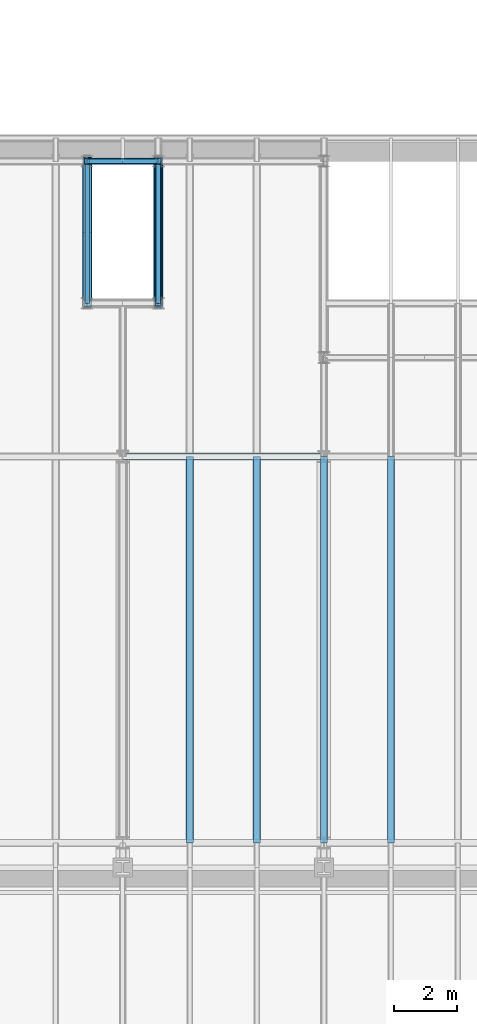
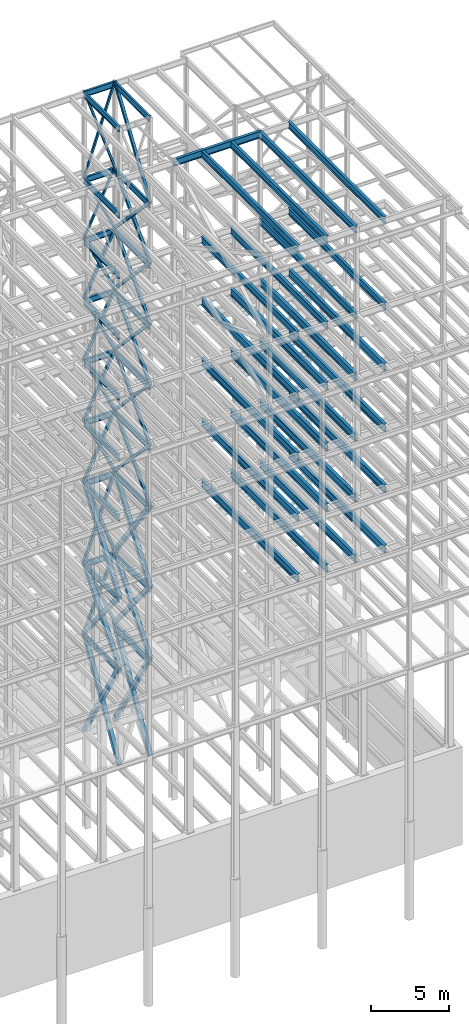
# One storey, part 144 of 150: 89 beams.
"""IFC2X3 building model written with IfcOpenShell, lengths in millimetres."""

from ifc_helpers import new_model, si_unit, frame, origin_with_axes, origin_2d_with_axis, place, context, subcontext, project, spatial, hollow_rectangle, i_section, extrude, material, type_object, element, save


model = new_model("IFC2X3")

# Units and contexts
model_context = context("Model", 3, precision=1e-05, world=origin_with_axes())
body_context = subcontext(model_context, "Body", "Model", "MODEL_VIEW")
ifc_project = project(units=[si_unit("LENGTHUNIT", "METRE", prefix="MILLI"), si_unit("AREAUNIT", "SQUARE_METRE"), si_unit("VOLUMEUNIT", "CUBIC_METRE"), si_unit("MASSUNIT", "GRAM", prefix="KILO"), si_unit("TIMEUNIT", "SECOND"), si_unit("PLANEANGLEUNIT", "RADIAN"), si_unit("SOLIDANGLEUNIT", "STERADIAN"), si_unit("THERMODYNAMICTEMPERATUREUNIT", "DEGREE_CELSIUS"), si_unit("LUMINOUSINTENSITYUNIT", "LUMEN")], contexts=[model_context])

# Site, building, storey
site_placement = place(None, origin_with_axes())
site = spatial("IfcSite", under=ifc_project, at=site_placement, CompositionType="ELEMENT")
building_placement = place(site_placement, origin_with_axes())
building = spatial("IfcBuilding", under=site, at=building_placement, Name="Undefined", CompositionType="ELEMENT")
storey_placement = place(building_placement, origin_with_axes())
storey = spatial("IfcBuildingStorey", under=building, at=storey_placement, Name="Undefined", CompositionType="ELEMENT", Elevation=0.0)

# Beams
ifc_material_1 = material()
beam_type_1 = type_object("IfcBeamType", Name="HSS8X8X3/8", PredefinedType="NOTDEFINED")
for number, where, z_axis, x_axis, name in (
    (1, (76923.9, 31877.0, 40309.8), (0.0, 0.722473115379788, 0.691399014718291), (0.0, -0.691399014718292, 0.722473115379787), "BEAM"),
    (2, (76923.9, 27355.8, 40309.8), (0.0, -0.722473115379788, 0.691399014718291), (0.0, 0.691399014718292, 0.722473115379787), "BEAM"),
    (3, (76923.9, 31877.0, 35585.4), (0.0, 0.722473115379788, 0.691399014718291), (0.0, -0.691399014718292, 0.722473115379787), "BEAM"),
    (4, (76923.9, 27355.8, 35585.4), (0.0, -0.722473115379788, 0.691399014718291), (0.0, 0.691399014718292, 0.722473115379787), "BEAM"),
):
    element("IfcBeam", number, at=place(storey_placement, frame(where, z_axis=z_axis, x_axis=x_axis)), inside=storey, type_object=beam_type_1, material=ifc_material_1, Name=name, ObjectType="HSS8X8X3/8", context=body_context, shape_type="SweptSolid", body=[
        extrude(hollow_rectangle(XDim=203.2, YDim=203.2, WallThickness=9.525, InnerFilletRadius=9.5249, OuterFilletRadius=19.0499, at=origin_2d_with_axis()), frame((6539.20521164461, 0.0, -3.62998809435833e-13), z_axis=(-1.0, 0.0, 0.0), x_axis=(0.0, -1.0, 0.0)), (0.0, 0.0, 1.0), 6539.20521164461),
    ])
for number, where, z_axis, x_axis, name in (
    (5, (76923.9, 31877.0, 40309.8), (0.902052163935922, 0.0, 0.431627030592989), (-0.431627030592989, 0.0, 0.902052163935922), "BEAM"),
    (6, (74663.3, 31877.0, 40309.8), (-0.902052163935922, 0.0, 0.431627030592989), (0.431627030592989, 0.0, 0.902052163935922), "BEAM"),
):
    element("IfcBeam", number, at=place(storey_placement, frame(where, z_axis=z_axis, x_axis=x_axis)), inside=storey, type_object=beam_type_1, material=ifc_material_1, Name=name, ObjectType="HSS8X8X3/8", context=body_context, shape_type="SweptSolid", body=[
        extrude(hollow_rectangle(XDim=203.2, YDim=203.2, WallThickness=9.525, InnerFilletRadius=9.5249, OuterFilletRadius=19.0499, at=origin_2d_with_axis()), frame((5237.3913086574, 0.0, -7.27595761418343e-12), z_axis=(-1.0, 0.0, 0.0), x_axis=(0.0, -1.0, 0.0)), (0.0, 0.0, 1.0), 5237.3913086574),
    ])
beam_1_placement = place(storey_placement, frame((76923.8996893509, 31877.0, 35585.399916514), z_axis=(0.902052163935922, 0.0, 0.431627030592989), x_axis=(-0.431627030592989, 0.0, 0.902052163935922)))
element("IfcBeam", 7, at=beam_1_placement, inside=storey, type_object=beam_type_1, material=ifc_material_1, Name="BEAM", ObjectType="HSS8X8X3/8", context=body_context, shape_type="SweptSolid", body=[
    extrude(hollow_rectangle(XDim=203.2, YDim=203.2, WallThickness=9.525, InnerFilletRadius=9.5249, OuterFilletRadius=19.0499, at=origin_2d_with_axis()), frame((5237.3912468091, 3.63797880709171e-12, 0.0), z_axis=(-1.0, 0.0, 0.0), x_axis=(0.0, -1.0, 0.0)), (0.0, 0.0, 1.0), 5237.39124988153),
])
beam_2_placement = place(storey_placement, frame((74663.3003106491, 31877.0, 35585.399916514), z_axis=(-0.902052163935922, 0.0, 0.431627030592989), x_axis=(0.431627030592989, 0.0, 0.902052163935922)))
element("IfcBeam", 8, at=beam_2_placement, inside=storey, type_object=beam_type_1, material=ifc_material_1, Name="BEAM", ObjectType="HSS8X8X3/8", context=body_context, shape_type="SweptSolid", body=[
    extrude(hollow_rectangle(XDim=203.2, YDim=203.2, WallThickness=9.525, InnerFilletRadius=9.5249, OuterFilletRadius=19.0499, at=origin_2d_with_axis()), frame((5237.3912468091, 3.63797880709171e-12, 0.0), z_axis=(-1.0, 0.0, 0.0), x_axis=(0.0, -1.0, 0.0)), (0.0, 0.0, 1.0), 5237.39124988152),
])
ifc_material_2 = material(Name="STEEL/A992")
beam_type_2 = type_object("IfcBeamType", Name="W18X35", PredefinedType="NOTDEFINED")
beam_3_placement = place(storey_placement, frame((74663.3, 27355.8, 65687.575), z_axis=(0.0, 0.0, 1.0), x_axis=(0.0, 1.0, 0.0)))
element("IfcBeam", 9, at=beam_3_placement, inside=storey, type_object=beam_type_2, material=ifc_material_2, Name="BEAM", ObjectType="W18X35", context=body_context, shape_type="SweptSolid", body=[
    extrude(i_section(OverallWidth=152.4, OverallDepth=450.85, WebThickness=7.9375, FlangeThickness=10.795, FilletRadius=17.78, at=origin_2d_with_axis()), frame((4521.20000000001, 0.0, 0.0), z_axis=(-1.0, 0.0, 0.0), x_axis=(0.0, -1.0, 0.0)), (0.0, 0.0, 1.0), 4521.20000000001),
])
beam_4_placement = place(storey_placement, frame((74663.3, 31877.0, 65687.575), z_axis=(0.0, 0.0, 1.0), x_axis=(1.0, 0.0, 0.0)))
element("IfcBeam", 10, at=beam_4_placement, inside=storey, type_object=beam_type_2, material=ifc_material_2, Name="BEAM", ObjectType="W18X35", context=body_context, shape_type="SweptSolid", body=[
    extrude(i_section(OverallWidth=152.4, OverallDepth=450.85, WebThickness=7.9375, FlangeThickness=10.795, FilletRadius=17.78, at=origin_2d_with_axis()), frame((2260.60000000001, 0.0, 0.0), z_axis=(-1.0, 0.0, 0.0), x_axis=(0.0, -1.0, 0.0)), (0.0, 0.0, 1.0), 2260.60000000001),
])
for number, where, z_axis, x_axis, name in (
    (11, (76923.9, 27355.8, 65687.575), (0.0, 0.0, 1.0), (0.0, 1.0, 0.0), "BEAM"),
    (12, (74663.3, 27355.8, 58981.975), (0.0, 0.0, 1.0), (0.0, 1.0, 0.0), "BEAM"),
):
    element("IfcBeam", number, at=place(storey_placement, frame(where, z_axis=z_axis, x_axis=x_axis)), inside=storey, type_object=beam_type_2, material=ifc_material_2, Name=name, ObjectType="W18X35", context=body_context, shape_type="SweptSolid", body=[
        extrude(i_section(OverallWidth=152.4, OverallDepth=450.85, WebThickness=7.9375, FlangeThickness=10.795, FilletRadius=17.78, at=origin_2d_with_axis()), frame((4521.20000000001, 0.0, 0.0), z_axis=(-1.0, 0.0, 0.0), x_axis=(0.0, -1.0, 0.0)), (0.0, 0.0, 1.0), 4521.20000000001),
    ])
beam_5_placement = place(storey_placement, frame((74663.3, 31877.0, 58981.975), z_axis=(0.0, 0.0, 1.0), x_axis=(1.0, 0.0, 0.0)))
element("IfcBeam", 13, at=beam_5_placement, inside=storey, type_object=beam_type_2, material=ifc_material_2, Name="BEAM", ObjectType="W18X35", context=body_context, shape_type="SweptSolid", body=[
    extrude(i_section(OverallWidth=152.4, OverallDepth=450.85, WebThickness=7.9375, FlangeThickness=10.795, FilletRadius=17.78, at=origin_2d_with_axis()), frame((2260.60000000001, 0.0, 0.0), z_axis=(-1.0, 0.0, 0.0), x_axis=(0.0, -1.0, 0.0)), (0.0, 0.0, 1.0), 2260.60000000001),
])
beam_6_placement = place(storey_placement, frame((76923.9, 27355.8, 58981.975), z_axis=(0.0, 0.0, 1.0), x_axis=(0.0, 1.0, 0.0)))
element("IfcBeam", 14, at=beam_6_placement, inside=storey, type_object=beam_type_2, material=ifc_material_2, Name="BEAM", ObjectType="W18X35", context=body_context, shape_type="SweptSolid", body=[
    extrude(i_section(OverallWidth=152.4, OverallDepth=450.85, WebThickness=7.9375, FlangeThickness=10.795, FilletRadius=17.78, at=origin_2d_with_axis()), frame((4521.20000000001, 0.0, 0.0), z_axis=(-1.0, 0.0, 0.0), x_axis=(0.0, -1.0, 0.0)), (0.0, 0.0, 1.0), 4521.20000000001),
])
beam_7_placement = place(storey_placement, frame((74663.3, 31877.0, 54257.575), z_axis=(0.0, 0.0, 1.0), x_axis=(1.0, 0.0, 0.0)))
element("IfcBeam", 15, at=beam_7_placement, inside=storey, type_object=beam_type_2, material=ifc_material_2, Name="BEAM", ObjectType="W18X35", context=body_context, shape_type="SweptSolid", body=[
    extrude(i_section(OverallWidth=152.4, OverallDepth=450.85, WebThickness=7.9375, FlangeThickness=10.795, FilletRadius=17.78, at=origin_2d_with_axis()), frame((2260.60000000001, 0.0, 0.0), z_axis=(-1.0, 0.0, 0.0), x_axis=(0.0, -1.0, 0.0)), (0.0, 0.0, 1.0), 2260.60000000001),
])
for number, where, z_axis, x_axis, name in (
    (16, (76923.9, 27355.8, 54257.575), (0.0, 0.0, 1.0), (0.0, 1.0, 0.0), "BEAM"),
    (17, (74663.3, 31877.0, 54257.575), (0.0, 0.0, 1.0), (0.0, -1.0, 0.0), "BEAM"),
):
    element("IfcBeam", number, at=place(storey_placement, frame(where, z_axis=z_axis, x_axis=x_axis)), inside=storey, type_object=beam_type_2, material=ifc_material_2, Name=name, ObjectType="W18X35", context=body_context, shape_type="SweptSolid", body=[
        extrude(i_section(OverallWidth=152.4, OverallDepth=450.85, WebThickness=7.9375, FlangeThickness=10.795, FilletRadius=17.78, at=origin_2d_with_axis()), frame((4521.20000000001, 0.0, 0.0), z_axis=(-1.0, 0.0, 0.0), x_axis=(0.0, -1.0, 0.0)), (0.0, 0.0, 1.0), 4521.20000000001),
    ])
beam_8_placement = place(storey_placement, frame((74663.3, 31877.0, 49533.175), z_axis=(0.0, 0.0, 1.0), x_axis=(1.0, 0.0, 0.0)))
element("IfcBeam", 18, at=beam_8_placement, inside=storey, type_object=beam_type_2, material=ifc_material_2, Name="BEAM", ObjectType="W18X35", context=body_context, shape_type="SweptSolid", body=[
    extrude(i_section(OverallWidth=152.4, OverallDepth=450.85, WebThickness=7.9375, FlangeThickness=10.795, FilletRadius=17.78, at=origin_2d_with_axis()), frame((2260.60000000001, 0.0, 0.0), z_axis=(-1.0, 0.0, 0.0), x_axis=(0.0, -1.0, 0.0)), (0.0, 0.0, 1.0), 2260.60000000001),
])
for number, where, z_axis, x_axis, name in (
    (19, (76923.9, 27355.8, 49533.175), (0.0, 0.0, 1.0), (0.0, 1.0, 0.0), "BEAM"),
    (20, (74663.3, 31877.0, 49533.175), (0.0, 0.0, 1.0), (0.0, -1.0, 0.0), "BEAM"),
):
    element("IfcBeam", number, at=place(storey_placement, frame(where, z_axis=z_axis, x_axis=x_axis)), inside=storey, type_object=beam_type_2, material=ifc_material_2, Name=name, ObjectType="W18X35", context=body_context, shape_type="SweptSolid", body=[
        extrude(i_section(OverallWidth=152.4, OverallDepth=450.85, WebThickness=7.9375, FlangeThickness=10.795, FilletRadius=17.78, at=origin_2d_with_axis()), frame((4521.20000000001, 0.0, 0.0), z_axis=(-1.0, 0.0, 0.0), x_axis=(0.0, -1.0, 0.0)), (0.0, 0.0, 1.0), 4521.20000000001),
    ])
beam_9_placement = place(storey_placement, frame((74663.3, 31877.0, 44808.775), z_axis=(0.0, 0.0, 1.0), x_axis=(1.0, 0.0, 0.0)))
element("IfcBeam", 21, at=beam_9_placement, inside=storey, type_object=beam_type_2, material=ifc_material_2, Name="BEAM", ObjectType="W18X35", context=body_context, shape_type="SweptSolid", body=[
    extrude(i_section(OverallWidth=152.4, OverallDepth=450.85, WebThickness=7.9375, FlangeThickness=10.795, FilletRadius=17.78, at=origin_2d_with_axis()), frame((2260.60000000001, 0.0, 0.0), z_axis=(-1.0, 0.0, 0.0), x_axis=(0.0, -1.0, 0.0)), (0.0, 0.0, 1.0), 2260.60000000001),
])
for number, where, z_axis, x_axis, name in (
    (22, (76923.9, 27355.8, 44808.775), (0.0, 0.0, 1.0), (0.0, 1.0, 0.0), "BEAM"),
    (23, (74663.3, 31877.0, 44808.775), (0.0, 0.0, 1.0), (0.0, -1.0, 0.0), "BEAM"),
):
    element("IfcBeam", number, at=place(storey_placement, frame(where, z_axis=z_axis, x_axis=x_axis)), inside=storey, type_object=beam_type_2, material=ifc_material_2, Name=name, ObjectType="W18X35", context=body_context, shape_type="SweptSolid", body=[
        extrude(i_section(OverallWidth=152.4, OverallDepth=450.85, WebThickness=7.9375, FlangeThickness=10.795, FilletRadius=17.78, at=origin_2d_with_axis()), frame((4521.20000000001, 0.0, 0.0), z_axis=(-1.0, 0.0, 0.0), x_axis=(0.0, -1.0, 0.0)), (0.0, 0.0, 1.0), 4521.20000000001),
    ])
beam_10_placement = place(storey_placement, frame((74663.3, 31877.0, 40084.375), z_axis=(0.0, 0.0, 1.0), x_axis=(1.0, 0.0, 0.0)))
element("IfcBeam", 24, at=beam_10_placement, inside=storey, type_object=beam_type_2, material=ifc_material_2, Name="BEAM", ObjectType="W18X35", context=body_context, shape_type="SweptSolid", body=[
    extrude(i_section(OverallWidth=152.4, OverallDepth=450.85, WebThickness=7.9375, FlangeThickness=10.795, FilletRadius=17.78, at=origin_2d_with_axis()), frame((2260.60000000001, 0.0, 0.0), z_axis=(-1.0, 0.0, 0.0), x_axis=(0.0, -1.0, 0.0)), (0.0, 0.0, 1.0), 2260.60000000001),
])
for number, where, z_axis, x_axis, name in (
    (25, (76923.9, 27355.8, 40084.375), (0.0, 0.0, 1.0), (0.0, 1.0, 0.0), "BEAM"),
    (26, (74663.3, 31877.0, 40084.375), (0.0, 0.0, 1.0), (0.0, -1.0, 0.0), "BEAM"),
    (27, (76923.9, 27355.8, 35359.975), (0.0, 0.0, 1.0), (0.0, 1.0, 0.0), "BEAM"),
    (28, (74663.3, 31877.0, 35359.975), (0.0, 0.0, 1.0), (0.0, -1.0, 0.0), "BEAM"),
):
    element("IfcBeam", number, at=place(storey_placement, frame(where, z_axis=z_axis, x_axis=x_axis)), inside=storey, type_object=beam_type_2, material=ifc_material_2, Name=name, ObjectType="W18X35", context=body_context, shape_type="SweptSolid", body=[
        extrude(i_section(OverallWidth=152.4, OverallDepth=450.85, WebThickness=7.9375, FlangeThickness=10.795, FilletRadius=17.78, at=origin_2d_with_axis()), frame((4521.20000000001, 0.0, 0.0), z_axis=(-1.0, 0.0, 0.0), x_axis=(0.0, -1.0, 0.0)), (0.0, 0.0, 1.0), 4521.20000000001),
    ])
beam_11_placement = place(storey_placement, frame((74663.3, 31877.0, 35359.975), z_axis=(0.0, 0.0, 1.0), x_axis=(1.0, 0.0, 0.0)))
element("IfcBeam", 29, at=beam_11_placement, inside=storey, type_object=beam_type_2, material=ifc_material_2, Name="BEAM", ObjectType="W18X35", context=body_context, shape_type="SweptSolid", body=[
    extrude(i_section(OverallWidth=152.4, OverallDepth=450.85, WebThickness=7.9375, FlangeThickness=10.795, FilletRadius=17.78, at=origin_2d_with_axis()), frame((2260.60000000001, 0.0, 0.0), z_axis=(-1.0, 0.0, 0.0), x_axis=(0.0, -1.0, 0.0)), (0.0, 0.0, 1.0), 2260.60000000001),
])
for number, where, z_axis, x_axis, name in (
    (30, (76923.9, 27355.8, 29060.775), (0.0, 0.0, 1.0), (0.0, 1.0, 0.0), "BEAM"),
    (31, (74663.3, 27355.8, 29060.775), (0.0, 0.0, 1.0), (0.0, 1.0, 0.0), "BEAM"),
):
    element("IfcBeam", number, at=place(storey_placement, frame(where, z_axis=z_axis, x_axis=x_axis)), inside=storey, type_object=beam_type_2, material=ifc_material_2, Name=name, ObjectType="W18X35", context=body_context, shape_type="SweptSolid", body=[
        extrude(i_section(OverallWidth=152.4, OverallDepth=450.85, WebThickness=7.9375, FlangeThickness=10.795, FilletRadius=17.78, at=origin_2d_with_axis()), frame((4521.20000000001, 0.0, 0.0), z_axis=(-1.0, 0.0, 0.0), x_axis=(0.0, -1.0, 0.0)), (0.0, 0.0, 1.0), 4521.20000000001),
    ])
beam_12_placement = place(storey_placement, frame((74663.3, 31877.0, 29060.775), z_axis=(0.0, 0.0, 1.0), x_axis=(1.0, 0.0, 0.0)))
element("IfcBeam", 32, at=beam_12_placement, inside=storey, type_object=beam_type_2, material=ifc_material_2, Name="BEAM", ObjectType="W18X35", context=body_context, shape_type="SweptSolid", body=[
    extrude(i_section(OverallWidth=152.4, OverallDepth=450.85, WebThickness=7.9375, FlangeThickness=10.795, FilletRadius=17.78, at=origin_2d_with_axis()), frame((2260.60000000001, 0.0, 0.0), z_axis=(-1.0, 0.0, 0.0), x_axis=(0.0, -1.0, 0.0)), (0.0, 0.0, 1.0), 2260.60000000001),
])
beam_type_3 = type_object("IfcBeamType", Name="HSS8X8X1/4", PredefinedType="NOTDEFINED")
beam_13_placement = place(storey_placement, frame((76923.9, 27355.8, 59207.4), z_axis=(0.0, -0.829139853379412, 0.559041235990662), x_axis=(0.0, 0.559041235990663, 0.829139853379412)))
element("IfcBeam", 33, at=beam_13_placement, inside=storey, type_object=beam_type_3, material=ifc_material_1, Name="BEAM", ObjectType="HSS8X8X1/4", context=body_context, shape_type="SweptSolid", body=[
    extrude(hollow_rectangle(XDim=203.2, YDim=203.2, WallThickness=6.35, InnerFilletRadius=6.3499, OuterFilletRadius=12.6999, at=origin_2d_with_axis()), frame((8087.41743698197, 0.0, 4.48941852414617e-13), z_axis=(-1.0, 0.0, 0.0), x_axis=(0.0, -1.0, 0.0)), (0.0, 0.0, 1.0), 8087.41743698196),
])
for number, where, z_axis, x_axis, name in (
    (34, (76923.9, 31877.0, 54483.0), (0.0, 0.722473115379788, 0.691399014718291), (0.0, -0.691399014718292, 0.722473115379787), "BEAM"),
    (35, (76923.9, 27355.8, 54483.0), (0.0, -0.722473115379788, 0.691399014718291), (0.0, 0.691399014718292, 0.722473115379787), "BEAM"),
    (36, (76923.9, 31877.0, 49758.6), (0.0, 0.722473115379788, 0.691399014718291), (0.0, -0.691399014718292, 0.722473115379787), "BEAM"),
    (37, (76923.9, 27355.8, 49758.6), (0.0, -0.722473115379788, 0.691399014718291), (0.0, 0.691399014718292, 0.722473115379787), "BEAM"),
    (38, (76923.9, 31877.0, 45034.2), (0.0, 0.722473115379788, 0.691399014718291), (0.0, -0.691399014718292, 0.722473115379787), "BEAM"),
    (39, (76923.9, 27355.8, 45034.2), (0.0, -0.722473115379788, 0.691399014718291), (0.0, 0.691399014718292, 0.722473115379787), "BEAM"),
):
    element("IfcBeam", number, at=place(storey_placement, frame(where, z_axis=z_axis, x_axis=x_axis)), inside=storey, type_object=beam_type_3, material=ifc_material_1, Name=name, ObjectType="HSS8X8X1/4", context=body_context, shape_type="SweptSolid", body=[
        extrude(hollow_rectangle(XDim=203.2, YDim=203.2, WallThickness=6.35, InnerFilletRadius=6.3499, OuterFilletRadius=12.6999, at=origin_2d_with_axis()), frame((6539.20521164461, 0.0, -3.62998809435833e-13), z_axis=(-1.0, 0.0, 0.0), x_axis=(0.0, -1.0, 0.0)), (0.0, 0.0, 1.0), 6539.20521164461),
    ])
for number, where, z_axis, x_axis, name in (
    (40, (76923.9, 31877.0, 49758.6), (0.902052163935922, 0.0, 0.431627030592989), (-0.431627030592989, 0.0, 0.902052163935922), "BEAM"),
    (41, (74663.3, 31877.0, 49758.6), (-0.902052163935922, 0.0, 0.431627030592989), (0.431627030592989, 0.0, 0.902052163935922), "BEAM"),
    (42, (76923.9, 31877.0, 45034.2), (0.902052163935922, 0.0, 0.431627030592989), (-0.431627030592989, 0.0, 0.902052163935922), "BEAM"),
    (43, (74663.3, 31877.0, 45034.2), (-0.902052163935922, 0.0, 0.431627030592989), (0.431627030592989, 0.0, 0.902052163935922), "BEAM"),
):
    element("IfcBeam", number, at=place(storey_placement, frame(where, z_axis=z_axis, x_axis=x_axis)), inside=storey, type_object=beam_type_3, material=ifc_material_1, Name=name, ObjectType="HSS8X8X1/4", context=body_context, shape_type="SweptSolid", body=[
        extrude(hollow_rectangle(XDim=203.2, YDim=203.2, WallThickness=6.35, InnerFilletRadius=6.3499, OuterFilletRadius=12.6999, at=origin_2d_with_axis()), frame((5237.3913086574, 0.0, -7.27595761418343e-12), z_axis=(-1.0, 0.0, 0.0), x_axis=(0.0, -1.0, 0.0)), (0.0, 0.0, 1.0), 5237.3913086574),
    ])
beam_type_4 = type_object("IfcBeamType", Name="HSS12X12X5/8", PredefinedType="NOTDEFINED")
beam_14_placement = place(storey_placement, frame((76923.9, 31877.0, 29286.2), z_axis=(0.0, 0.812403320128227, 0.583095914446871), x_axis=(0.0, -0.583095914446872, 0.812403320128227)))
element("IfcBeam", 44, at=beam_14_placement, inside=storey, type_object=beam_type_4, material=ifc_material_1, Name="BEAM", ObjectType="HSS12X12X5/8", context=body_context, shape_type="SweptSolid", body=[
    extrude(hollow_rectangle(XDim=304.8, YDim=304.8, WallThickness=15.875, InnerFilletRadius=15.875, OuterFilletRadius=31.75, at=origin_2d_with_axis()), frame((7753.78424254892, 0.0, 0.0), z_axis=(-1.0, 0.0, 0.0), x_axis=(0.0, -1.0, 0.0)), (0.0, 0.0, 1.0), 7753.78424254892),
])
beam_15_placement = place(storey_placement, frame((76923.9, 27355.8, 29286.2), z_axis=(0.0, -0.812403320128227, 0.583095914446871), x_axis=(0.0, 0.583095914446872, 0.812403320128227)))
element("IfcBeam", 45, at=beam_15_placement, inside=storey, type_object=beam_type_4, material=ifc_material_1, Name="BEAM", ObjectType="HSS12X12X5/8", context=body_context, shape_type="SweptSolid", body=[
    extrude(hollow_rectangle(XDim=304.8, YDim=304.8, WallThickness=15.875, InnerFilletRadius=15.875, OuterFilletRadius=31.75, at=origin_2d_with_axis()), frame((7753.78424254892, 0.0, 0.0), z_axis=(-1.0, 0.0, 0.0), x_axis=(0.0, -1.0, 0.0)), (0.0, 0.0, 1.0), 7753.78424254893),
])
beam_16_placement = place(storey_placement, frame((76923.9, 31877.0, 23774.4), z_axis=(0.0, 0.773162940146034, 0.634207432930851), x_axis=(0.0, -0.634207432930851, 0.773162940146034)))
element("IfcBeam", 46, at=beam_16_placement, inside=storey, type_object=beam_type_4, material=ifc_material_1, Name="BEAM", ObjectType="HSS12X12X5/8", context=body_context, shape_type="SweptSolid", body=[
    extrude(hollow_rectangle(XDim=304.8, YDim=304.8, WallThickness=15.875, InnerFilletRadius=15.875, OuterFilletRadius=31.75, at=origin_2d_with_axis()), frame((7128.89813926388, 0.0, 0.0), z_axis=(-1.0, 0.0, 0.0), x_axis=(0.0, -1.0, 0.0)), (0.0, 0.0, 1.0), 7128.89813926388),
])
beam_17_placement = place(storey_placement, frame((76923.9, 27355.8, 23774.4), z_axis=(0.0, -0.773162940146034, 0.634207432930851), x_axis=(0.0, 0.634207432930851, 0.773162940146035)))
element("IfcBeam", 47, at=beam_17_placement, inside=storey, type_object=beam_type_4, material=ifc_material_1, Name="BEAM", ObjectType="HSS12X12X5/8", context=body_context, shape_type="SweptSolid", body=[
    extrude(hollow_rectangle(XDim=304.8, YDim=304.8, WallThickness=15.875, InnerFilletRadius=15.875, OuterFilletRadius=31.75, at=origin_2d_with_axis()), frame((7128.89813926388, 0.0, 0.0), z_axis=(-1.0, 0.0, 0.0), x_axis=(0.0, -1.0, 0.0)), (0.0, 0.0, 1.0), 7128.89813926389),
])
beam_18_placement = place(storey_placement, frame((76923.9, 31877.0, 16154.4), z_axis=(0.0, 0.860012047706723, 0.510273728305985), x_axis=(0.0, -0.510273728305984, 0.860012047706723)))
element("IfcBeam", 48, at=beam_18_placement, inside=storey, type_object=beam_type_4, material=ifc_material_1, Name="BEAM", ObjectType="HSS12X12X5/8", context=body_context, shape_type="SweptSolid", body=[
    extrude(hollow_rectangle(XDim=304.8, YDim=304.8, WallThickness=15.875, InnerFilletRadius=15.875, OuterFilletRadius=31.75, at=origin_2d_with_axis()), frame((8860.34138394227, 0.0, 9.83695501049183e-13), z_axis=(-1.0, 0.0, 0.0), x_axis=(0.0, -1.0, 0.0)), (0.0, 0.0, 1.0), 8860.34138394227),
])
beam_19_placement = place(storey_placement, frame((76923.9, 27355.8, 16154.4), z_axis=(0.0, -0.860012047706723, 0.510273728305985), x_axis=(0.0, 0.510273728305984, 0.860012047706723)))
element("IfcBeam", 49, at=beam_19_placement, inside=storey, type_object=beam_type_4, material=ifc_material_1, Name="BEAM", ObjectType="HSS12X12X5/8", context=body_context, shape_type="SweptSolid", body=[
    extrude(hollow_rectangle(XDim=304.8, YDim=304.8, WallThickness=15.875, InnerFilletRadius=15.875, OuterFilletRadius=31.75, at=origin_2d_with_axis()), frame((8860.34138394227, 0.0, 9.83695501049183e-13), z_axis=(-1.0, 0.0, 0.0), x_axis=(0.0, -1.0, 0.0)), (0.0, 0.0, 1.0), 8860.34138394226),
])
beam_20_placement = place(storey_placement, frame((74663.3, 27355.8, 29286.2), z_axis=(0.0, -0.812403320128227, 0.583095914446871), x_axis=(0.0, 0.583095914446872, 0.812403320128227)))
element("IfcBeam", 50, at=beam_20_placement, inside=storey, type_object=beam_type_4, material=ifc_material_1, Name="BEAM", ObjectType="HSS12X12X5/8", context=body_context, shape_type="SweptSolid", body=[
    extrude(hollow_rectangle(XDim=304.8, YDim=304.8, WallThickness=15.875, InnerFilletRadius=15.875, OuterFilletRadius=31.75, at=origin_2d_with_axis()), frame((7753.78424254892, 0.0, 0.0), z_axis=(-1.0, 0.0, 0.0), x_axis=(0.0, -1.0, 0.0)), (0.0, 0.0, 1.0), 7753.78424254893),
])
for number, where, z_axis, x_axis, name in (
    (51, (74663.3, 31877.0, 23774.4), (0.0, 0.773162940146034, 0.634207432930851), (0.0, -0.634207432930851, 0.773162940146034), "BEAM"),
    (52, (74663.3, 27355.8, 23774.4), (0.0, -0.773162940146034, 0.634207432930851), (0.0, 0.634207432930851, 0.773162940146035), "BEAM"),
):
    element("IfcBeam", number, at=place(storey_placement, frame(where, z_axis=z_axis, x_axis=x_axis)), inside=storey, type_object=beam_type_4, material=ifc_material_1, Name=name, ObjectType="HSS12X12X5/8", context=body_context, shape_type="SweptSolid", body=[
        extrude(hollow_rectangle(XDim=304.8, YDim=304.8, WallThickness=15.875, InnerFilletRadius=15.875, OuterFilletRadius=31.75, at=origin_2d_with_axis()), frame((7128.89813926388, 0.0, 0.0), z_axis=(-1.0, 0.0, 0.0), x_axis=(0.0, -1.0, 0.0)), (0.0, 0.0, 1.0), 7128.89813926388),
    ])
for number, where, z_axis, x_axis, name in (
    (53, (74663.3, 31877.0, 16154.4), (0.0, 0.860012047706723, 0.510273728305985), (0.0, -0.510273728305984, 0.860012047706723), "BEAM"),
    (54, (74663.3, 27355.8, 16154.4), (0.0, -0.860012047706723, 0.510273728305985), (0.0, 0.510273728305984, 0.860012047706723), "BEAM"),
):
    element("IfcBeam", number, at=place(storey_placement, frame(where, z_axis=z_axis, x_axis=x_axis)), inside=storey, type_object=beam_type_4, material=ifc_material_1, Name=name, ObjectType="HSS12X12X5/8", context=body_context, shape_type="SweptSolid", body=[
        extrude(hollow_rectangle(XDim=304.8, YDim=304.8, WallThickness=15.875, InnerFilletRadius=15.875, OuterFilletRadius=31.75, at=origin_2d_with_axis()), frame((8860.34138394227, 0.0, 9.83695501049183e-13), z_axis=(-1.0, 0.0, 0.0), x_axis=(0.0, -1.0, 0.0)), (0.0, 0.0, 1.0), 8860.34138394227),
    ])
beam_type_5 = type_object("IfcBeamType", Name="HSS8X8X1/2", PredefinedType="NOTDEFINED")
for number, where, z_axis, x_axis, name in (
    (55, (76923.9, 31877.0, 29286.2), (0.941225625809532, 0.0, 0.337778509262289), (-0.337778509262291, 0.0, 0.941225625809532), "BEAM"),
    (56, (74663.3, 31877.0, 29286.2), (-0.941225625809532, 0.0, 0.337778509262289), (0.337778509262291, 0.0, 0.941225625809532), "BEAM"),
):
    element("IfcBeam", number, at=place(storey_placement, frame(where, z_axis=z_axis, x_axis=x_axis)), inside=storey, type_object=beam_type_5, material=ifc_material_1, Name=name, ObjectType="HSS8X8X1/2", context=body_context, shape_type="SweptSolid", body=[
        extrude(hollow_rectangle(XDim=203.2, YDim=203.2, WallThickness=12.7, InnerFilletRadius=12.6999, OuterFilletRadius=25.3999, at=origin_2d_with_axis()), frame((6692.55056013774, 0.0, 0.0), z_axis=(-1.0, 0.0, 0.0), x_axis=(0.0, -1.0, 0.0)), (0.0, 0.0, 1.0), 6692.55056013774),
    ])
for number, where, z_axis, x_axis, name in (
    (57, (76923.9, 31877.0, 23774.4), (0.925207030744495, 0.0, 0.379462712609493), (-0.379462712609491, 0.0, 0.925207030744496), "BEAM"),
    (58, (74663.3, 31877.0, 23774.4), (-0.925207030744495, 0.0, 0.379462712609493), (0.37946271260949, 0.0, 0.925207030744496), "BEAM"),
):
    element("IfcBeam", number, at=place(storey_placement, frame(where, z_axis=z_axis, x_axis=x_axis)), inside=storey, type_object=beam_type_5, material=ifc_material_1, Name=name, ObjectType="HSS8X8X1/2", context=body_context, shape_type="SweptSolid", body=[
        extrude(hollow_rectangle(XDim=203.2, YDim=203.2, WallThickness=12.7, InnerFilletRadius=12.6999, OuterFilletRadius=25.3999, at=origin_2d_with_axis()), frame((5957.36952018255, 3.63797880709171e-12, -3.30700440375339e-13), z_axis=(-1.0, 0.0, 0.0), x_axis=(0.0, -1.0, 0.0)), (0.0, 0.0, 1.0), 5957.36952018255),
    ])
beam_type_6 = type_object("IfcBeamType", Name="HSS6X6X1/4", PredefinedType="NOTDEFINED")
for number, where, z_axis, x_axis, name in (
    (59, (76923.9, 31877.0, 59207.4), (0.94760099793907, 0.0, 0.319456333017328), (-0.31945633301733, 0.0, 0.94760099793907), "BEAM"),
    (60, (74663.3, 31877.0, 59207.4), (-0.94760099793907, 0.0, 0.319456333017328), (0.319456333017332, 0.0, 0.947600997939069), "BEAM"),
):
    element("IfcBeam", number, at=place(storey_placement, frame(where, z_axis=z_axis, x_axis=x_axis)), inside=storey, type_object=beam_type_6, material=ifc_material_1, Name=name, ObjectType="HSS6X6X1/4", context=body_context, shape_type="SweptSolid", body=[
        extrude(hollow_rectangle(XDim=152.4, YDim=152.4, WallThickness=6.35, InnerFilletRadius=6.3499, OuterFilletRadius=12.6999, at=origin_2d_with_axis()), frame((7076.39623819922, -3.63797880709171e-12, 1.45519152283669e-11), z_axis=(-1.0, 0.0, 0.0), x_axis=(0.0, -1.0, 0.0)), (0.0, 0.0, 1.0), 7076.39623819922),
    ])
for number, where, z_axis, x_axis, name in (
    (61, (76923.9, 31877.0, 54483.0), (0.902052163935922, 0.0, 0.431627030592989), (-0.431627030592989, 0.0, 0.902052163935922), "BEAM"),
    (62, (74663.3, 31877.0, 54483.0), (-0.902052163935922, 0.0, 0.431627030592989), (0.431627030592989, 0.0, 0.902052163935922), "BEAM"),
):
    element("IfcBeam", number, at=place(storey_placement, frame(where, z_axis=z_axis, x_axis=x_axis)), inside=storey, type_object=beam_type_6, material=ifc_material_1, Name=name, ObjectType="HSS6X6X1/4", context=body_context, shape_type="SweptSolid", body=[
        extrude(hollow_rectangle(XDim=152.4, YDim=152.4, WallThickness=6.35, InnerFilletRadius=6.3499, OuterFilletRadius=12.6999, at=origin_2d_with_axis()), frame((5237.3913086574, 0.0, -7.27595761418343e-12), z_axis=(-1.0, 0.0, 0.0), x_axis=(0.0, -1.0, 0.0)), (0.0, 0.0, 1.0), 5237.39130865739),
    ])
beam_type_7 = type_object("IfcBeamType", Name="W24X68", PredefinedType="NOTDEFINED")
for number, where, z_axis, x_axis, name in (
    (63, (84328.0, 10185.4, 54181.375), (0.0, 0.0, 1.0), (0.0, 1.0, 0.0), "BEAM"),
    (64, (82194.4, 10185.4, 54181.375), (0.0, 0.0, 1.0), (0.0, 1.0, 0.0), "BEAM"),
    (65, (80060.8, 10185.4, 54181.375), (0.0, 0.0, 1.0), (0.0, 1.0, 0.0), "BEAM"),
    (66, (77927.2, 10185.4, 54181.375), (0.0, 0.0, 1.0), (0.0, 1.0, 0.0), "BEAM"),
    (67, (84328.0, 10185.4, 49456.975), (0.0, 0.0, 1.0), (0.0, 1.0, 0.0), "BEAM"),
    (68, (82194.4, 10185.4, 49456.975), (0.0, 0.0, 1.0), (0.0, 1.0, 0.0), "BEAM"),
    (69, (80060.8, 10185.4, 49456.975), (0.0, 0.0, 1.0), (0.0, 1.0, 0.0), "BEAM"),
    (70, (77927.2, 10185.4, 49456.975), (0.0, 0.0, 1.0), (0.0, 1.0, 0.0), "BEAM"),
    (71, (84328.0, 10185.4, 44732.575), (0.0, 0.0, 1.0), (0.0, 1.0, 0.0), "BEAM"),
    (72, (82194.4, 10185.4, 44732.575), (0.0, 0.0, 1.0), (0.0, 1.0, 0.0), "BEAM"),
    (73, (80060.8, 10185.4, 44732.575), (0.0, 0.0, 1.0), (0.0, 1.0, 0.0), "BEAM"),
    (74, (77927.2, 10185.4, 44732.575), (0.0, 0.0, 1.0), (0.0, 1.0, 0.0), "BEAM"),
    (75, (84328.0, 10185.4, 40008.175), (0.0, 0.0, 1.0), (0.0, 1.0, 0.0), "BEAM"),
    (76, (82194.4, 10185.4, 40008.175), (0.0, 0.0, 1.0), (0.0, 1.0, 0.0), "BEAM"),
    (77, (80060.8, 10185.4, 40008.175), (0.0, 0.0, 1.0), (0.0, 1.0, 0.0), "BEAM"),
    (78, (77927.2, 10185.4, 40008.175), (0.0, 0.0, 1.0), (0.0, 1.0, 0.0), "BEAM"),
):
    element("IfcBeam", number, at=place(storey_placement, frame(where, z_axis=z_axis, x_axis=x_axis)), inside=storey, type_object=beam_type_7, material=ifc_material_2, Name=name, ObjectType="W24X68", context=body_context, shape_type="SweptSolid", body=[
        extrude(i_section(OverallWidth=227.838, OverallDepth=603.25, WebThickness=11.1125, FlangeThickness=14.859, FilletRadius=23.2409, at=origin_2d_with_axis()), frame((12293.6, 0.0, 0.0), z_axis=(-1.0, 0.0, 0.0), x_axis=(0.0, -1.0, 0.0)), (0.0, 0.0, 1.0), 12293.6),
    ])
beam_type_8 = type_object("IfcBeamType", Name="W21X55", PredefinedType="NOTDEFINED")
for number, where, z_axis, x_axis, name in (
    (79, (84328.0, 10185.4, 65649.475), (0.0, 0.0, 1.0), (0.0, 1.0, 0.0), "BEAM"),
    (80, (82194.4, 10185.4, 65649.475), (0.0, 0.0, 1.0), (0.0, 1.0, 0.0), "BEAM"),
):
    element("IfcBeam", number, at=place(storey_placement, frame(where, z_axis=z_axis, x_axis=x_axis)), inside=storey, type_object=beam_type_8, material=ifc_material_2, Name=name, ObjectType="W21X55", context=body_context, shape_type="SweptSolid", body=[
        extrude(i_section(OverallWidth=208.788, OverallDepth=527.05, WebThickness=9.5, FlangeThickness=13.2588, FilletRadius=16.8624, at=origin_2d_with_axis()), frame((12293.6, 0.0, 0.0), z_axis=(-1.0, 0.0, 0.0), x_axis=(0.0, -1.0, 0.0)), (0.0, 0.0, 1.0), 12293.6),
    ])
beam_21_placement = place(storey_placement, frame((75793.6, 22479.0, 65649.475), z_axis=(0.0, 0.0, 1.0), x_axis=(1.0, 0.0, 0.0)))
element("IfcBeam", 81, at=beam_21_placement, inside=storey, type_object=beam_type_8, material=ifc_material_2, Name="BEAM", ObjectType="W21X55", context=body_context, shape_type="SweptSolid", body=[
    extrude(i_section(OverallWidth=208.788, OverallDepth=527.05, WebThickness=9.5, FlangeThickness=13.2588, FilletRadius=16.8624, at=origin_2d_with_axis()), frame((6400.80000000001, 0.0, 0.0), z_axis=(-1.0, 0.0, 0.0), x_axis=(0.0, -1.0, 0.0)), (0.0, 0.0, 1.0), 6400.8),
])
for number, where, z_axis, x_axis, name in (
    (82, (80060.8, 10185.4, 65649.475), (0.0, 0.0, 1.0), (0.0, 1.0, 0.0), "BEAM"),
    (83, (77927.2, 10185.4, 65649.475), (0.0, 0.0, 1.0), (0.0, 1.0, 0.0), "BEAM"),
    (84, (84328.0, 10185.4, 58943.875), (0.0, 0.0, 1.0), (0.0, 1.0, 0.0), "BEAM"),
    (85, (82194.4, 10185.4, 58943.875), (0.0, 0.0, 1.0), (0.0, 1.0, 0.0), "BEAM"),
    (86, (80060.8, 10185.4, 58943.875), (0.0, 0.0, 1.0), (0.0, 1.0, 0.0), "BEAM"),
    (87, (77927.2, 10185.4, 58943.875), (0.0, 0.0, 1.0), (0.0, 1.0, 0.0), "BEAM"),
):
    element("IfcBeam", number, at=place(storey_placement, frame(where, z_axis=z_axis, x_axis=x_axis)), inside=storey, type_object=beam_type_8, material=ifc_material_2, Name=name, ObjectType="W21X55", context=body_context, shape_type="SweptSolid", body=[
        extrude(i_section(OverallWidth=208.788, OverallDepth=527.05, WebThickness=9.5, FlangeThickness=13.2588, FilletRadius=16.8624, at=origin_2d_with_axis()), frame((12293.6, 0.0, 0.0), z_axis=(-1.0, 0.0, 0.0), x_axis=(0.0, -1.0, 0.0)), (0.0, 0.0, 1.0), 12293.6),
    ])
beam_type_9 = type_object("IfcBeamType", Name="W18X40", PredefinedType="NOTDEFINED")
beam_22_placement = place(storey_placement, frame((74663.3, 27355.8, 23547.3875), z_axis=(0.0, 0.0, 1.0), x_axis=(0.0, 1.0, 0.0)))
element("IfcBeam", 88, at=beam_22_placement, inside=storey, type_object=beam_type_9, material=ifc_material_2, Name="BEAM", ObjectType="W18X40", context=body_context, shape_type="SweptSolid", body=[
    extrude(i_section(OverallWidth=152.908, OverallDepth=454.025, WebThickness=7.9375, FlangeThickness=13.335, FilletRadius=16.8274, at=origin_2d_with_axis()), frame((4521.20000000001, 0.0, 0.0), z_axis=(-1.0, 0.0, 0.0), x_axis=(0.0, -1.0, 0.0)), (0.0, 0.0, 1.0), 4521.20000000001),
])
beam_type_10 = type_object("IfcBeamType", Name="W24X55", PredefinedType="NOTDEFINED")
beam_23_placement = place(storey_placement, frame((76923.9, 27355.8, 23474.3625), z_axis=(0.0, 0.0, 1.0), x_axis=(0.0, 1.0, 0.0)))
element("IfcBeam", 89, at=beam_23_placement, inside=storey, type_object=beam_type_10, material=ifc_material_2, Name="BEAM", ObjectType="W24X55", context=body_context, shape_type="SweptSolid", body=[
    extrude(i_section(OverallWidth=178.054, OverallDepth=600.075, WebThickness=9.5249, FlangeThickness=12.827, FilletRadius=23.6854, at=origin_2d_with_axis()), frame((4521.20000000001, 0.0, 0.0), z_axis=(-1.0, 0.0, 0.0), x_axis=(0.0, -1.0, 0.0)), (0.0, 0.0, 1.0), 4521.20000000001),
])

save(model, "model.ifc")
